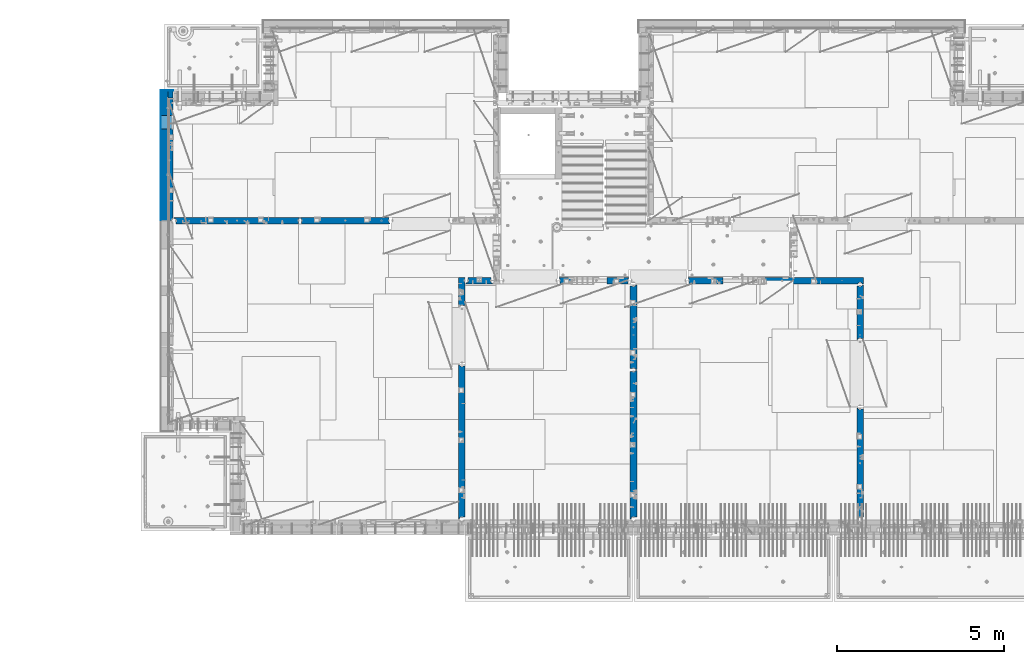
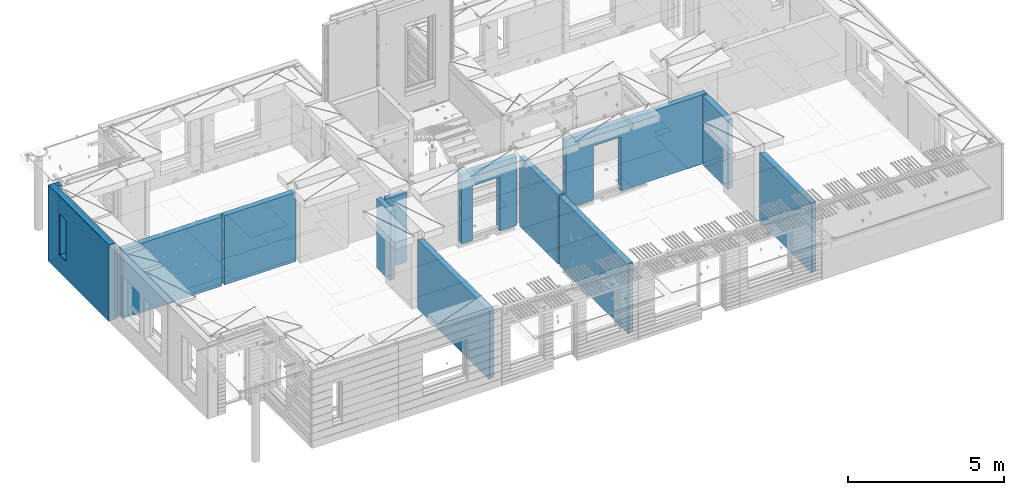
# One storey, part 235 of 352: 16 walls, 12 elements without a shape of their own.
"""IFC2X3 building model written with IfcOpenShell, lengths in millimetres."""

from ifc_helpers import new_model, si_unit, frame, origin_with_axes, place, context, subcontext, project, spatial, faceted_brep, material, type_object, element, aggregate, save


model = new_model("IFC2X3")

# Units and contexts
model_context = context("Model", 3, precision=1e-05, world=origin_with_axes())
body_context = subcontext(model_context, "Body", "Model", "MODEL_VIEW")
ifc_project = project(units=[si_unit("LENGTHUNIT", "METRE", prefix="MILLI"), si_unit("AREAUNIT", "SQUARE_METRE"), si_unit("VOLUMEUNIT", "CUBIC_METRE"), si_unit("MASSUNIT", "GRAM", prefix="KILO"), si_unit("TIMEUNIT", "SECOND"), si_unit("PLANEANGLEUNIT", "RADIAN"), si_unit("SOLIDANGLEUNIT", "STERADIAN"), si_unit("THERMODYNAMICTEMPERATUREUNIT", "DEGREE_CELSIUS"), si_unit("LUMINOUSINTENSITYUNIT", "LUMEN")], contexts=[model_context])

# Site, building, storey
site_placement = place(None, origin_with_axes())
site = spatial("IfcSite", under=ifc_project, at=site_placement, CompositionType="ELEMENT")
building_placement = place(site_placement, origin_with_axes())
building = spatial("IfcBuilding", under=site, at=building_placement, CompositionType="ELEMENT")
storey_placement = place(building_placement, origin_with_axes())
storey = spatial("IfcBuildingStorey", under=building, at=storey_placement, Name="6", CompositionType="ELEMENT", Elevation=0.0)

# Assembly, wall
assembly_1_placement = place(storey_placement, origin_with_axes())
assembly_1 = element("IfcElementAssembly", 1, at=assembly_1_placement, inside=storey, AssemblyPlace="NOTDEFINED", PredefinedType="REINFORCEMENT_UNIT")
ifc_material_1 = material(Name="CONCRETE/C25/30")
wall_type_1 = type_object("IfcWallType", PredefinedType="NOTDEFINED")
wall_1_placement = place(assembly_1_placement, frame((28610.0, 13387.9996249472, 98112.5), z_axis=(0.0, 0.0, 1.0), x_axis=(0.0, 1.0, 0.0)))
wall_1 = element("IfcWall", 2, at=wall_1_placement, type_object=wall_type_1, material=ifc_material_1, context=body_context, shape_type="Brep", body=[
    faceted_brep([(30.9999999999982, 70.0000000000073, 1357.5), (30.9999999999982, 70.0000000000073, -1357.5), (60.9999999999982, 57.0000000000036, -1357.5), (60.9999999999982, 57.0000000000036, 1357.5), (60.9999999999982, -100.0, 1357.5), (60.9999999999982, -100.0, -1357.5), (30.9999999999982, 100.0, -1357.5), (30.9999999999982, 100.0, 1357.5), (1631.00037505278, 100.0, 1357.5), (1631.00037505278, 100.0, -1357.5), (1631.00037505278, -56.9999999999964, 1357.5), (1631.00037505278, -56.9999999999964, -1357.5), (1661.00037505278, -70.0, 1357.5), (1661.00037505278, -70.0, -1357.5), (1661.00037505278, -100.0, 1357.5), (1661.00037505278, -100.0, -1357.5)], [[[0, 1, 2, 3]], [[4, 3, 2, 5]], [[6, 7, 8, 9]], [[10, 11, 9, 8]], [[12, 13, 11, 10]], [[14, 15, 13, 12]], [[15, 14, 4, 5]], [[1, 6, 9, 11, 13, 15, 5, 2]], [[7, 6, 1, 0]], [[14, 12, 10, 8, 7, 0, 3, 4]]]),
])
aggregate(assembly_1, [wall_1])

assembly_2_placement = place(storey_placement, origin_with_axes())
assembly_2 = element("IfcElementAssembly", 3, at=assembly_2_placement, inside=storey, AssemblyPlace="NOTDEFINED", PredefinedType="REINFORCEMENT_UNIT")
wall_2_placement = place(assembly_2_placement, frame((28610.0, 8000.0, 98112.5), z_axis=(0.0, 0.0, 1.0), x_axis=(0.0, 1.0, 0.0)))
wall_2 = element("IfcWall", 4, at=wall_2_placement, type_object=wall_type_1, material=ifc_material_1, context=body_context, shape_type="Brep", body=[
    faceted_brep([(30.0000000000009, 70.0, 1357.5), (30.0, 70.0, -1357.5), (80.0, 57.0, -1357.5), (79.99999955967, 57.0000001052285, 1357.5), (79.9999996695051, -100.0, 1357.5), (80.0, -100.0, -1357.5), (30.0, 100.0, -1357.5), (30.0000000000009, 100.0, 1357.5), (3360.0, 100.0, 1357.5), (3360.0, 100.0, -1357.5), (3360.0, 70.0000000000073, 1357.5), (3360.0, 70.0000000000073, -1357.5), (3330.0, 57.0000000000036, 1357.5), (3330.0, 57.0000000000036, -1357.5), (3330.0, -100.0, 1357.5), (3330.0, -100.0, -1357.5)], [[[0, 1, 2, 3]], [[4, 3, 2, 5]], [[6, 7, 8, 9]], [[9, 8, 10, 11]], [[12, 13, 11, 10]], [[14, 15, 13, 12]], [[15, 14, 4, 5]], [[1, 6, 9, 11, 13, 15, 5, 2]], [[7, 6, 1, 0]], [[14, 12, 10, 8, 7, 0, 3, 4]]]),
])
aggregate(assembly_2, [wall_2])

assembly_3_placement = place(storey_placement, origin_with_axes())
assembly_3 = element("IfcElementAssembly", 5, at=assembly_3_placement, inside=storey, AssemblyPlace="NOTDEFINED", PredefinedType="REINFORCEMENT_UNIT")
wall_3_placement = place(assembly_3_placement, frame((23410.0002919986, 15180.0, 98112.5), z_axis=(0.0, 0.0, 1.0), x_axis=(1.0, 0.0, 0.0)))
wall_3 = element("IfcWall", 6, at=wall_3_placement, type_object=wall_type_1, material=ifc_material_1, context=body_context, shape_type="Brep", body=[
    faceted_brep([(3134.99885559082, 100.0, 762.5), (3147.99885559082, 80.0, 762.5), (3251.99885559082, 80.0, 762.5), (3264.99885559082, 100.0, 762.5), (3147.99885559082, 80.0, 1357.5), (3134.99885559082, 100.0, 1357.5), (3251.99885559082, 80.0, 1357.5), (3264.99885559082, 100.0, 1357.5), (5299.99970800144, -100.0, -1357.5), (5299.99970800144, -100.0, 1357.5), (5264.99970800144, -100.0, 1357.5), (5264.99970800144, -100.0, -1357.5), (5251.99970800144, -70.0, 1357.5), (5251.99970800144, -70.0, -1357.5), (5147.99970800144, -70.0, 1357.5), (5147.99970800144, -70.0, -1357.5), (5134.99970800144, -100.0, 1357.5), (5134.99970800144, -100.0, -1357.5), (59.9988535092562, -100.0, 1357.5), (59.9988535092562, -100.0, -1357.5), (1090.00039464695, -100.0, -1357.5), (1090.00039464695, -100.0, 762.5), (2110.00039464695, -100.0, 762.5), (2110.00039464695, -100.0, -1357.5), (59.9988535092562, 57.0, 1357.5), (59.9988535092562, 57.0, -1357.5), (29.9988535092562, 70.0000000000018, 1357.5), (29.9988535092562, 70.0000000000018, -1357.5), (29.9988535092562, 100.0, 1357.5), (29.9988535092562, 100.0, -1357.5), (1090.00039464695, 100.0, -1357.5), (1090.00039464695, 100.0, 762.5), (2110.00039464695, 100.0, 762.5), (2110.00039464695, 100.0, -1357.5), (5299.99970800144, 100.0, -1357.5), (5299.99970800144, 100.0, 1357.5)], [[[0, 1, 2, 3]], [[4, 1, 0, 5]], [[6, 2, 1, 4]], [[7, 3, 2, 6]], [[8, 9, 10, 11]], [[10, 12, 13, 11]], [[14, 15, 13, 12]], [[16, 17, 15, 14]], [[17, 16, 18, 19, 20, 21, 22, 23]], [[24, 25, 19, 18]], [[26, 27, 25, 24]], [[28, 29, 27, 26]], [[19, 25, 27, 29, 30, 20]], [[31, 21, 20, 30]], [[32, 22, 21, 31]], [[33, 23, 22, 32]], [[34, 8, 11, 13, 15, 17, 23, 33]], [[9, 8, 34, 35]], [[4, 5, 28, 26, 24, 18, 16, 14, 12, 10, 9, 35, 7, 6]], [[35, 34, 33, 32, 31, 30, 29, 28, 5, 0, 3, 7]]]),
])
aggregate(assembly_3, [wall_3])

assembly_4_placement = place(storey_placement, origin_with_axes())
assembly_4 = element("IfcElementAssembly", 7, at=assembly_4_placement, inside=storey, AssemblyPlace="NOTDEFINED", PredefinedType="REINFORCEMENT_UNIT")
wall_4_placement = place(assembly_4_placement, frame((21810.0, 12500.0, 98112.5), z_axis=(0.0, 0.0, 1.0), x_axis=(0.0, 1.0, 0.0)))
wall_4 = element("IfcWall", 8, at=wall_4_placement, type_object=wall_type_1, material=ifc_material_1, context=body_context, shape_type="Brep", body=[
    faceted_brep([(2519.9998239177, -57.0, 1357.5), (2519.9998239177, -57.0, -1357.5), (2519.9998239177, 100.0, -1357.5), (2519.9998239177, 100.0, 1357.5), (2549.9998239177, -70.0, 1357.5), (2549.9998239177, -70.0, -1357.5), (45.0, 100.0, 1357.5), (45.0, 100.0, -1357.5), (45.0, -57.0, -1357.5), (45.0, -57.0, 1357.5), (15.0, -70.0, 1357.5), (15.0, -70.0000000000036, -1357.5), (15.0, -100.0, -1357.5), (15.0, -100.0, 1357.5), (2549.9998239177, -100.0, -1357.5), (2549.9998239177, -100.0, 1357.5)], [[[0, 1, 2, 3]], [[4, 5, 1, 0]], [[6, 7, 8, 9]], [[10, 9, 8, 11]], [[12, 13, 10, 11]], [[13, 12, 14, 15]], [[3, 6, 9, 10, 13, 15, 4, 0]], [[7, 6, 3, 2]], [[14, 12, 11, 8, 7, 2, 1, 5]], [[15, 14, 5, 4]]]),
])
aggregate(assembly_4, [wall_4])

assembly_5_placement = place(storey_placement, origin_with_axes())
assembly_5 = element("IfcElementAssembly", 9, at=assembly_5_placement, inside=storey, AssemblyPlace="NOTDEFINED", PredefinedType="REINFORCEMENT_UNIT")
wall_5_placement = place(assembly_5_placement, frame((21810.0, 8000.0, 98112.5), z_axis=(0.0, 0.0, 1.0), x_axis=(0.0, 1.0, 0.0)))
wall_5 = element("IfcWall", 10, at=wall_5_placement, type_object=wall_type_1, material=ifc_material_1, context=body_context, shape_type="Brep", body=[
    faceted_brep([(30.0000000000009, 70.0, 1357.5), (30.0, 70.0, -1357.5), (80.0, 57.0, -1357.5), (79.99999955967, 57.0000001052285, 1357.5), (79.9999996695051, -100.0, 1357.5), (80.0, -100.0, -1357.5), (30.0, 100.0, -1357.5), (30.0000000000009, 100.0, 1357.5), (4455.0, 100.0, 1357.5), (4455.0, 100.0, -1357.5), (4455.0, -57.0, 1357.5), (4455.0, -57.0, -1357.5), (4485.0, -70.0000000000036, 1357.5), (4485.0, -70.0000000000036, -1357.5), (4485.0, -100.0, 1357.5), (4485.0, -100.0, -1357.5)], [[[0, 1, 2, 3]], [[4, 3, 2, 5]], [[6, 7, 8, 9]], [[10, 11, 9, 8]], [[12, 13, 11, 10]], [[14, 15, 13, 12]], [[15, 14, 4, 5]], [[1, 6, 9, 11, 13, 15, 5, 2]], [[7, 6, 1, 0]], [[14, 12, 10, 8, 7, 0, 3, 4]]]),
])
aggregate(assembly_5, [wall_5])

assembly_6_placement = place(storey_placement, origin_with_axes())
assembly_6 = element("IfcElementAssembly", 11, at=assembly_6_placement, inside=storey, AssemblyPlace="NOTDEFINED", PredefinedType="REINFORCEMENT_UNIT")
wall_6_placement = place(assembly_6_placement, frame((19569.9991455076, 15180.0000000001, 98112.5), z_axis=(0.0, 0.0, 1.0), x_axis=(1.0, 0.0, 0.0)))
wall_6 = element("IfcWall", 12, at=wall_6_placement, type_object=wall_type_1, material=ifc_material_1, context=body_context, shape_type="Brep", body=[
    faceted_brep([(30.0000000001819, 56.9999999999745, 1357.5), (30.0000000001819, 56.9999999999745, -1357.5), (30.0000000001819, -100.0, -1357.5), (30.0000000001819, -100.0, 1357.5), (0.0, 69.9999999999745, 1357.5), (0.0, 69.9999999999745, -1357.5), (1450.00154113788, 100.0, -1357.5), (1450.00154113788, -100.0, -1357.5), (1450.00154113788, -100.0, 762.5), (1450.00154113788, 100.0, 762.5), (430.001541137881, 100.0, 762.5), (430.001541137881, -100.0, 762.5), (430.001541137881, -100.0, -1357.5), (430.001541137881, 100.0, -1357.5), (0.0, 100.0, -1357.5), (0.0, 100.0, 1357.5), (2110.00085449221, 100.0, 1357.5), (2110.00085449221, 100.0, -1357.5), (2110.00085449272, 70.0000000037435, 1357.5), (2110.00085449221, 70.0000000037435, -1357.5), (2080.00085191853, -100.0, -1357.5), (2080.00085558004, 57.0000004585763, -1357.5), (2080.00085558004, 57.0000004585763, 1357.5), (2080.00085191853, -100.0, 1357.5)], [[[0, 1, 2, 3]], [[4, 5, 1, 0]], [[6, 7, 8, 9]], [[10, 11, 12, 13]], [[9, 8, 11, 10]], [[13, 14, 15, 16, 17, 6, 9, 10]], [[17, 16, 18, 19]], [[20, 7, 6, 17, 19, 21]], [[18, 22, 21, 19]], [[23, 20, 21, 22]], [[12, 11, 8, 7, 20, 23, 3, 2]], [[14, 13, 12, 2, 1, 5]], [[15, 14, 5, 4]], [[23, 22, 18, 16, 15, 4, 0, 3]]]),
])
aggregate(assembly_6, [wall_6])

assembly_7_placement = place(storey_placement, origin_with_axes())
assembly_7 = element("IfcElementAssembly", 13, at=assembly_7_placement, inside=storey, AssemblyPlace="NOTDEFINED", PredefinedType="REINFORCEMENT_UNIT")
wall_7_placement = place(assembly_7_placement, frame((16660.0, 8000.0, 98112.5), z_axis=(0.0, 0.0, 1.0), x_axis=(0.0, 1.0, 0.0)))
wall_7 = element("IfcWall", 14, at=wall_7_placement, type_object=wall_type_1, material=ifc_material_1, context=body_context, shape_type="Brep", body=[
    faceted_brep([(30.0000000000009, 70.0, 1357.5), (30.0, 70.0, -1357.5), (80.0, 57.0, -1357.5), (79.99999955967, 57.0000001052285, 1357.5), (79.9999996695051, -100.0, 1357.5), (80.0, -100.0, -1357.5), (30.0, 100.0, -1357.5), (30.0000000000009, 100.0, 1357.5), (4644.99239711402, 100.0, 1357.5), (4644.99239711402, 100.0, -1357.5), (4644.99653549905, 70.0145277302508, 1357.5), (4644.99653549905, 70.0145277302508, -1357.5), (4614.97833252975, 57.001718635147, 1357.5), (4614.97833252975, 57.001718635147, -1357.5), (4615.00000080787, -100.0, 1357.5), (4615.00000080787, -100.0, -1357.5)], [[[0, 1, 2, 3]], [[4, 3, 2, 5]], [[6, 7, 8, 9]], [[9, 8, 10, 11]], [[12, 13, 11, 10]], [[14, 15, 13, 12]], [[15, 14, 4, 5]], [[1, 6, 9, 11, 13, 15, 5, 2]], [[7, 6, 1, 0]], [[14, 12, 10, 8, 7, 0, 3, 4]]]),
])
aggregate(assembly_7, [wall_7])

assembly_8_placement = place(storey_placement, origin_with_axes())
assembly_8 = element("IfcElementAssembly", 15, at=assembly_8_placement, inside=storey, AssemblyPlace="NOTDEFINED", PredefinedType="REINFORCEMENT_UNIT")
wall_8_placement = place(assembly_8_placement, frame((16660.0, 14375.0001284873, 98112.5), z_axis=(0.0, 0.0, 1.0), x_axis=(0.0, 1.0, 0.0)))
wall_8 = element("IfcWall", 16, at=wall_8_placement, type_object=wall_type_1, material=ifc_material_1, context=body_context, shape_type="Brep", body=[
    faceted_brep([(59.9783637637502, 57.008280238686, -607.5), (29.9765698802239, 70.004139724977, -607.5), (29.972430061518, 100.0, -607.5), (84.972430061518, 100.0, -607.5), (84.972430061518, 50.0, -607.5), (59.9793309975266, 50.0, -607.5), (84.972430061518, 50.0, -1357.5), (84.972430061518, 100.0, -1357.5), (59.9793309975285, 50.0, -1357.5), (739.999871512746, -100.0, 1357.5), (752.999871512742, -80.0, 1357.5), (856.999871512742, -80.0, 1357.5), (869.99987151274, -100.0, 1357.5), (904.999871512742, -100.0, 1357.5), (904.999871512742, 100.0, 1357.5), (29.972430061518, 100.0, 1357.5), (29.9765698802239, 70.004139724977, 1357.5), (59.9783637637502, 57.008280238686, 1357.5), (60.0000329474624, -100.0, 1357.5), (739.999871512746, -100.0, -1357.5), (60.0000329474624, -100.0, -1357.5), (752.999871512742, -80.0, -1357.5), (856.999871512742, -80.0, -1357.5), (869.99987151274, -100.0, -1357.5), (904.999871512742, -100.0, -1357.5), (904.999871512742, 100.0, -1357.5)], [[[0, 1, 2, 3, 4, 5]], [[6, 4, 3, 7]], [[8, 5, 4, 6]], [[9, 10, 11, 12, 13, 14, 15, 16, 17, 18]], [[19, 9, 18, 20]], [[9, 19, 21, 10]], [[10, 21, 22, 11]], [[12, 11, 22, 23]], [[24, 13, 12, 23]], [[13, 24, 25, 14]], [[15, 14, 25, 7, 3, 2]], [[16, 15, 2, 1]], [[17, 16, 1, 0]], [[20, 18, 17, 0, 5, 8]], [[25, 24, 23, 22, 21, 19, 20, 8, 6, 7]]]),
])
aggregate(assembly_8, [wall_8])

assembly_9_placement = place(storey_placement, origin_with_axes())
assembly_9 = element("IfcElementAssembly", 17, at=assembly_9_placement, inside=storey, AssemblyPlace="NOTDEFINED", PredefinedType="REINFORCEMENT_UNIT")
wall_9_placement = place(assembly_9_placement, frame((16790.0, 15180.0, 98112.5), z_axis=(0.0, 0.0, 1.0), x_axis=(1.0, 0.0, 0.0)))
wall_9 = element("IfcWall", 18, at=wall_9_placement, type_object=wall_type_1, material=ifc_material_1, context=body_context, shape_type="Brep", body=[
    faceted_brep([(740.0, 100.0, 1357.5), (740.0, -57.0, 1357.5), (740.0, -57.0, -1357.5), (740.0, 100.0, -1357.5), (790.0, -70.0, 1357.5), (790.0, -69.9999999999982, -1357.5), (50.0, 100.0, 1357.5), (50.0, 100.0, -1357.5), (50.0, -48.3299999999999, -1357.5), (50.0, -48.3299999999999, 1357.5), (0.0, -69.996666666666, -1357.5), (0.0, -69.996666666666, 1357.5), (0.0, -100.0, -1357.5), (0.0, -100.0, 1357.5), (790.0, -100.0, -1357.5), (790.0, -100.0, 1357.5)], [[[0, 1, 2, 3]], [[4, 5, 2, 1]], [[6, 7, 8, 9]], [[9, 8, 10, 11]], [[12, 13, 11, 10]], [[13, 12, 14, 15]], [[1, 0, 6, 9, 11, 13, 15, 4]], [[7, 6, 0, 3]], [[14, 12, 10, 8, 7, 3, 2, 5]], [[15, 14, 5, 4]]]),
])
aggregate(assembly_9, [wall_9])

assembly_10_placement = place(storey_placement, origin_with_axes())
assembly_10 = element("IfcElementAssembly", 19, at=assembly_10_placement, inside=storey, AssemblyPlace="NOTDEFINED", PredefinedType="REINFORCEMENT_UNIT")
wall_10_placement = place(assembly_10_placement, frame((11795.0, 16980.0, 98112.5), z_axis=(0.0, 0.0, 1.0), x_axis=(1.0, 0.0, 0.0)))
wall_10 = element("IfcWall", 20, at=wall_10_placement, type_object=wall_type_1, material=ifc_material_1, context=body_context, shape_type="Brep", body=[
    faceted_brep([(2680.0, 100.0, 1357.5), (2680.0, -57.0, 1357.5), (2680.0, -57.0, -1357.50000000001), (2680.0, 100.0, -1357.5), (2705.0, -67.8333333333321, 1357.5), (2705.0, -67.8333333333321, -1357.5), (25.0, 100.0, 1357.5), (25.0, 100.0, -1357.5), (25.0, 70.0000000000036, -1357.5), (25.0, 70.0000000000036, 1357.5), (55.0, 57.0, -1357.5), (55.0, 57.0, 1357.5), (55.0, -100.0, -1357.5), (55.0, -100.0, 1357.5), (2705.0, -100.0, -1357.5), (2705.0, -100.0, 1357.5)], [[[0, 1, 2, 3]], [[4, 5, 2, 1]], [[6, 7, 8, 9]], [[9, 8, 10, 11]], [[11, 10, 12, 13]], [[14, 15, 13, 12]], [[0, 6, 9, 11, 13, 15, 4, 1]], [[7, 6, 0, 3]], [[14, 12, 10, 8, 7, 3, 2, 5]], [[15, 14, 5, 4]]]),
])
aggregate(assembly_10, [wall_10])

assembly_11_placement = place(storey_placement, origin_with_axes())
assembly_11 = element("IfcElementAssembly", 21, at=assembly_11_placement, inside=storey, AssemblyPlace="NOTDEFINED", PredefinedType="REINFORCEMENT_UNIT")
wall_11_placement = place(assembly_11_placement, frame((8000.0, 16980.0, 98112.5), z_axis=(0.0, 0.0, 1.0), x_axis=(1.0, 0.0, 0.0)))
wall_11 = element("IfcWall", 22, at=wall_11_placement, type_object=wall_type_1, material=ifc_material_1, context=body_context, shape_type="Brep", body=[
    faceted_brep([(80.0, 52.0, 1357.5), (80.0, 52.0, -1357.5), (80.0, -100.0, -1357.5), (79.9999996695051, -100.0, 1357.5), (30.0000022791291, 65.0, 1357.5), (30.0000022791291, 65.0, -1357.5), (30.0, 100.0, -1357.5), (30.0000000000009, 100.0, 1357.5), (3790.0, 100.0, 1357.5), (3790.0, 100.0, -1357.5), (3790.0, 70.0000000000036, 1357.5), (3790.0, 70.0000000000036, -1357.5), (3760.0, 57.0, 1357.5), (3760.0, 57.0, -1357.5), (3760.0, -100.0, 1357.5), (3760.0, -100.0, -1357.5)], [[[0, 1, 2, 3]], [[4, 5, 1, 0]], [[6, 7, 8, 9]], [[9, 8, 10, 11]], [[10, 12, 13, 11]], [[14, 15, 13, 12]], [[15, 14, 3, 2]], [[6, 9, 11, 13, 15, 2, 1, 5]], [[7, 6, 5, 4]], [[14, 12, 10, 8, 7, 4, 0, 3]]]),
])
aggregate(assembly_11, [wall_11])

# Assembly, walls
assembly_12_placement = place(storey_placement, origin_with_axes())
assembly_12 = element("IfcElementAssembly", 23, at=assembly_12_placement, inside=storey, AssemblyPlace="NOTDEFINED", PredefinedType="REINFORCEMENT_UNIT")
ifc_material_2 = material()
wall_type_2 = type_object("IfcWallType", PredefinedType="NOTDEFINED")
wall_12_placement = place(assembly_12_placement, frame((7850.0, 20764.9951872276, 98247.5), z_axis=(0.0, 0.0, 1.0), x_axis=(1.0, 0.0, 0.0)))
wall_12 = element("IfcWall", 24, at=wall_12_placement, type_object=wall_type_2, material=ifc_material_2, context=body_context, shape_type="Brep", body=[
    faceted_brep([(0.0, 110.0, -1492.5), (0.0, 110.0, 1492.5), (150.0, 110.0, 1492.5), (150.0, 110.0, -1492.5), (0.0, -110.0, 1492.5), (150.0, -110.0, 1492.5), (0.0, -110.0, -1492.5), (150.0, -110.0, -1492.5)], [[[0, 1, 2, 3]], [[1, 4, 5, 2]], [[4, 6, 7, 5]], [[6, 0, 3, 7]], [[5, 7, 3, 2]], [[6, 4, 1, 0]]]),
])
wall_13_placement = place(assembly_12_placement, frame((7740.0, 16980.0, 98247.5), z_axis=(0.0, 0.0, 1.0), x_axis=(0.0, 1.0, 0.0)))
wall_13 = element("IfcWall", 25, at=wall_13_placement, type_object=wall_type_2, material=ifc_material_2, context=body_context, shape_type="Brep", body=[
    faceted_brep([(5.0, -110.0, 1492.5), (5.0, -110.0, -1492.5), (3894.99518722756, -110.0, -1492.5), (3894.99518722756, -110.0, 1492.5), (2745.00189658477, -110.0, -802.5), (2745.00189658477, -110.0, 807.5), (3155.00189658477, -110.0, 807.5), (3155.00189658477, -110.0, -802.5), (5.0, 110.0, 1492.5), (3894.99518722756, 110.0, 1492.5), (5.0, 110.0, -1492.5), (3894.99518722756, 110.0, -1492.5), (2745.00189658477, 110.0, -802.5), (3155.00189658477, 110.0, -802.5), (3155.00189658477, 110.0, 807.5), (2745.00189658477, 110.0, 807.5)], [[[0, 1, 2, 3], [4, 5, 6, 7]], [[8, 0, 3, 9]], [[1, 0, 8, 10]], [[1, 10, 11, 2]], [[3, 2, 11, 9]], [[10, 8, 9, 11], [12, 13, 14, 15]], [[6, 14, 13, 7]], [[5, 15, 14, 6]], [[4, 12, 15, 5]], [[7, 13, 12, 4]]]),
])
wall_type_3 = type_object("IfcWallType", PredefinedType="NOTDEFINED")
wall_14_placement = place(assembly_12_placement, frame((7925.0, 16980.0, 98112.5), z_axis=(0.0, 0.0, 1.0), x_axis=(0.0, 1.0, 0.0)))
wall_14 = element("IfcWall", 26, at=wall_14_placement, type_object=wall_type_3, material=ifc_material_1, context=body_context, shape_type="Brep", body=[
    faceted_brep([(3155.00189658477, -74.9999998692319, -667.5), (3155.00189658477, 75.0, -667.5), (2745.00189658477, 75.0, -667.5), (2745.00189658477, -74.9999999986567, -667.5), (2745.00189658477, 75.0, 942.5), (2745.00189658477, -75.000000709987, 942.5), (3155.00189658477, 75.0, 942.5), (3155.00189658477, -75.0000005805623, 942.5), (3674.99518722756, -75.0, -1357.5), (3674.99518722756, -75.0, 1357.5), (3564.99519001209, -75.0000022791282, 1357.5), (3564.99519001209, -75.0, -1357.5), (3674.99518722756, 75.0, 1357.5), (5.0, 75.0, 1357.5), (5.0, -15.0000022791291, 1357.5), (65.0, -75.0, 1357.5), (3484.99518722756, -75.0000001199542, 1357.5), (3497.99518763813, -54.9999993903657, 1357.5), (3551.99518754267, -54.9999994175314, 1357.5), (5.0, 75.0, -1357.5), (5.0, -15.0000022791291, -1357.5), (65.0, -75.0, -1357.5), (3484.99518722756, -75.0, -1357.5), (3497.99518763813, -54.9999993903657, -1357.5), (3551.99518754267, -54.9999994175314, -1357.5), (3674.99518722756, 75.0, -1357.5)], [[[0, 1, 2, 3]], [[3, 2, 4, 5]], [[5, 4, 6, 7]], [[7, 6, 1, 0]], [[8, 9, 10, 11]], [[9, 12, 13, 14, 15, 16, 17, 18, 10]], [[13, 19, 20, 14]], [[15, 14, 20, 21]], [[15, 21, 22, 16], [3, 5, 7, 0]], [[16, 22, 23, 17]], [[17, 23, 24, 18]], [[10, 18, 24, 11]], [[23, 22, 21, 20, 19, 25, 8, 11, 24]], [[9, 8, 25, 12]], [[19, 13, 12, 25], [2, 1, 6, 4]]]),
])
ifc_material_3 = material(Name="CONCRETE/C30/37")
wall_type_4 = type_object("IfcWallType", PredefinedType="NOTDEFINED")
wall_15_placement = place(assembly_12_placement, frame((7630.0, 20879.9952125549, 98247.5), z_axis=(0.0, 0.0, 1.0), x_axis=(1.0, 0.0, 0.0)))
wall_15 = element("IfcWall", 27, at=wall_15_placement, type_object=wall_type_4, material=ifc_material_3, context=body_context, shape_type="Brep", body=[
    faceted_brep([(0.0, 5.0, -1492.5), (0.0, 5.0, 1492.5), (370.0, 5.0, 1492.5), (370.0, 5.0, -1492.5), (0.0, -5.0, 1492.5), (370.0, -5.0, 1492.5), (0.0, -5.0, -1492.5), (370.0, -5.0, -1492.5)], [[[0, 1, 2, 3]], [[1, 4, 5, 2]], [[4, 6, 7, 5]], [[6, 0, 3, 7]], [[5, 7, 3, 2]], [[6, 4, 1, 0]]]),
])
wall_16_placement = place(assembly_12_placement, frame((7625.0, 16980.0, 98247.5), z_axis=(0.0, 0.0, 1.0), x_axis=(0.0, 1.0, 0.0)))
wall_16 = element("IfcWall", 28, at=wall_16_placement, type_object=wall_type_4, material=ifc_material_3, context=body_context, shape_type="Brep", body=[
    faceted_brep([(5.0, -5.0, 1492.5), (5.0, -5.0, -1492.5), (3904.99518722756, -5.0, -1492.5), (3904.99518722756, -5.0, 1492.5), (2745.00189658477, -5.0, -802.5), (2745.00189658477, -5.0, 807.5), (3155.00189658477, -5.0, 807.5), (3155.00189658477, -5.0, -802.5), (5.0, 5.0, 1492.5), (3904.99518722756, 5.0, 1492.5), (5.0, 5.0, -1492.5), (3904.99518722756, 5.0, -1492.5), (2745.00189658477, 5.0, -802.5), (3155.00189658477, 5.0, -802.5), (3155.00189658477, 5.0, 807.5), (2745.00189658477, 5.0, 807.5)], [[[0, 1, 2, 3], [4, 5, 6, 7]], [[8, 0, 3, 9]], [[1, 0, 8, 10]], [[1, 10, 11, 2]], [[3, 2, 11, 9]], [[10, 8, 9, 11], [12, 13, 14, 15]], [[6, 14, 13, 7]], [[5, 15, 14, 6]], [[4, 12, 15, 5]], [[7, 13, 12, 4]]]),
])
aggregate(assembly_12, [wall_12, wall_15, wall_13, wall_16, wall_14])

save(model, "model.ifc")
